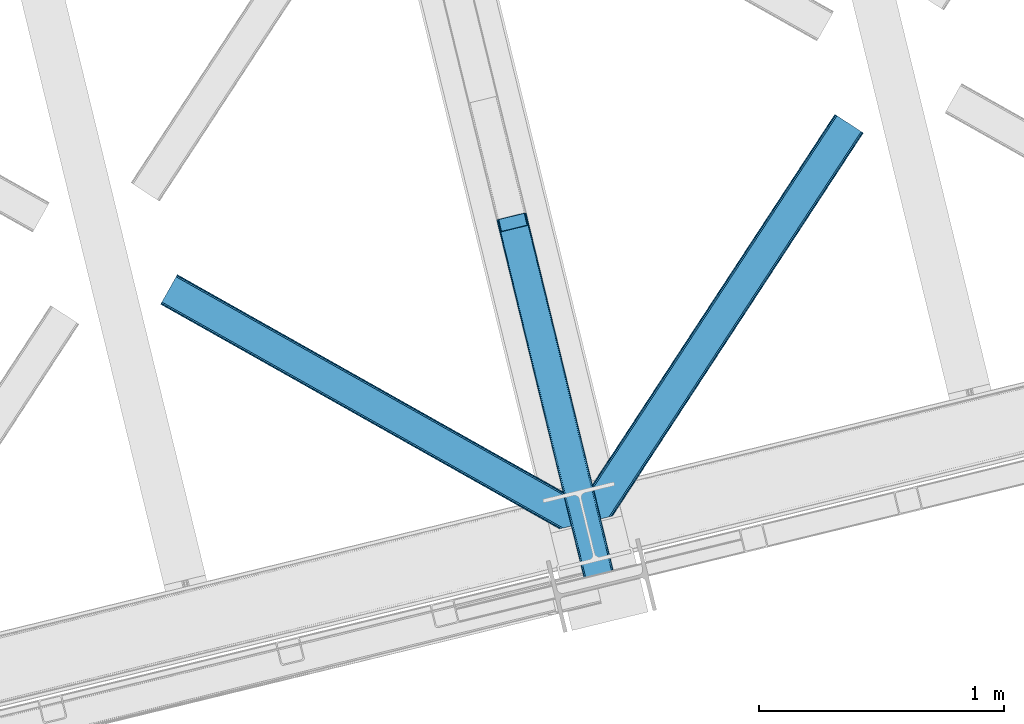
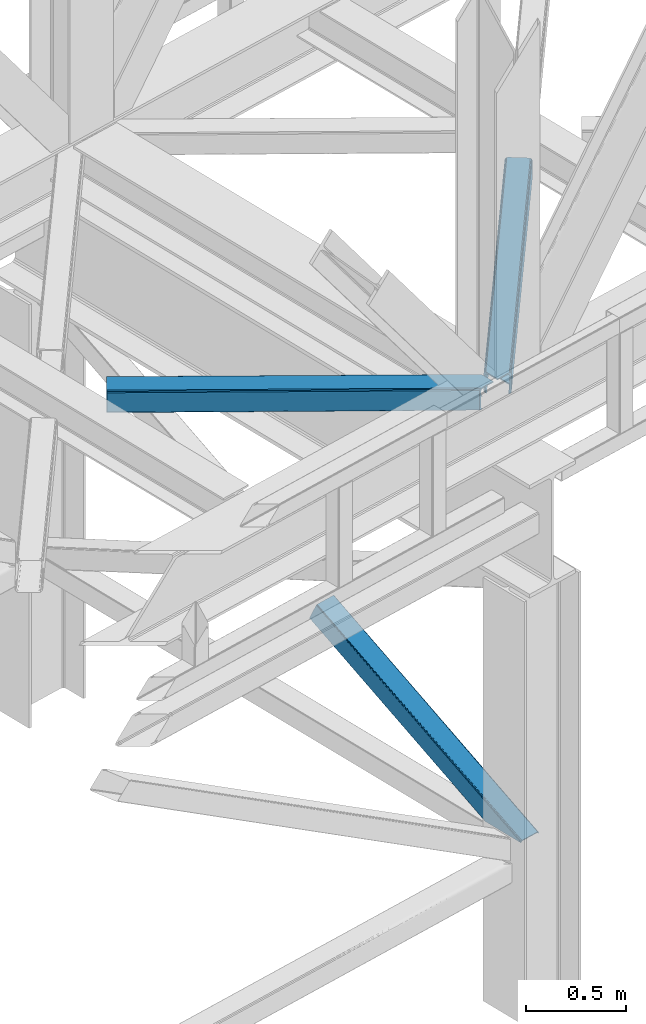
# One storey, part 50 of 93: 3 members.
"""IFC4 building model written with IfcOpenShell, lengths in millimetres."""

import ifcopenshell
import ifcopenshell.guid

model = None  # the IFC model being written
_history = None  # IfcOwnerHistory: only IFC2X3 demands one
_inside = {}  # id of a spatial element -> (the spatial element, [elements in it])
_under = {}  # id of a project, library or spatial element -> (it, [spatial elements below it])
_declared = {}  # id of a project -> (the project, [libraries it declares])
_typed = {}  # id of a type object -> (the type object, [elements of that type])
_made_of = {}  # id of a material, layer set ... -> (it, [elements and type objects made of it])


def new_model(schema):
    """Start an empty IFC model of exactly this schema.

    Asked for "IFC4X3", IfcOpenShell would pick the latest addendum, in which some entities
    have other attributes; the version numbers below select the first issue.
    IFC2X3 requires an IfcOwnerHistory on every rooted entity: one is made here for all.
    """
    global model, _history
    if schema == "IFC4X3":
        model = ifcopenshell.file(schema_version=(4, 3, 0, 0))
    else:
        model = ifcopenshell.file(schema=schema)
    _inside.clear()
    _under.clear()
    _declared.clear()
    _typed.clear()
    _made_of.clear()
    _history = None
    if model.schema == "IFC2X3":
        org = make("IfcOrganization", Name="unknown")
        user = make(
            "IfcPersonAndOrganization",
            ThePerson=make("IfcPerson", FamilyName="unknown"),
            TheOrganization=org,
        )
        app = make(
            "IfcApplication",
            ApplicationDeveloper=org,
            Version="unknown",
            ApplicationFullName="unknown",
            ApplicationIdentifier="unknown",
        )
        _history = make(
            "IfcOwnerHistory",
            OwningUser=user,
            OwningApplication=app,
            ChangeAction="ADDED",
            CreationDate=0,
        )
    return model


def make(cls, **values):
    """One entity of the class cls with the attributes given. An attribute that is None is left unset."""
    return model.create_entity(
        cls, **{name: value for name, value in values.items() if value is not None}
    )


def entity(cls, *values):
    """Any entity or typed value of the class cls, its attributes in the order of the schema. None: left unset."""
    e = model.create_entity(cls)
    for i, value in enumerate(values):
        if value is not None:
            e[i] = value
    return e


def rooted(cls, **values):
    """An entity with a GlobalId (a new one), such as an element, a storey or a relation."""
    return make(cls, GlobalId=ifcopenshell.guid.new(), OwnerHistory=_history, **values)


def si_unit(unit_type, name, prefix=None):
    """IfcSIUnit, for example si_unit("LENGTHUNIT", "METRE", prefix="MILLI")."""
    return make("IfcSIUnit", UnitType=unit_type, Prefix=prefix, Name=name)


def converted_unit(unit_type, name, factor, base, dimensions=None, offset=None):
    """IfcConversionBasedUnit, such as the inch: factor (a typed value) times the base unit."""
    return make(
        "IfcConversionBasedUnit"
        if offset is None
        else "IfcConversionBasedUnitWithOffset",
        ConversionOffset=offset,
        Dimensions=None
        if dimensions is None
        else entity("IfcDimensionalExponents", *dimensions),
        UnitType=unit_type,
        Name=name,
        ConversionFactor=make(
            "IfcMeasureWithUnit", ValueComponent=factor, UnitComponent=base
        ),
    )


def derived_unit(unit_type, elements):
    """IfcDerivedUnit: a product of units, each with its exponent."""
    return make(
        "IfcDerivedUnit",
        Elements=[
            make("IfcDerivedUnitElement", Unit=unit, Exponent=power)
            for unit, power in elements
        ],
        UnitType=unit_type,
    )


def assignment(units):
    """IfcUnitAssignment: the units of a project."""
    return None if units is None else make("IfcUnitAssignment", Units=units)


def point(xyz):
    """IfcCartesianPoint."""
    return None if xyz is None else make("IfcCartesianPoint", Coordinates=xyz)


def direction(xyz):
    """IfcDirection."""
    return None if xyz is None else make("IfcDirection", DirectionRatios=xyz)


def frame(location, z_axis=None, x_axis=None):
    """IfcAxis2Placement3D, a coordinate frame: its origin and axes. An axis left out is left unset."""
    return make(
        "IfcAxis2Placement3D",
        Location=point(location),
        Axis=direction(z_axis),
        RefDirection=direction(x_axis),
    )


def origin():
    """The frame at (0, 0, 0) with its axes left unset."""
    return frame((0.0, 0.0, 0.0))


def place(relative_to, where):
    """IfcLocalPlacement: puts the frame where relative to a parent placement (None: the world)."""
    return make(
        "IfcLocalPlacement", PlacementRelTo=relative_to, RelativePlacement=where
    )


def context(
    kind, dimensions, precision=None, world=None, true_north=None, identifier=None
):
    """IfcGeometricRepresentationContext, for example the 3D "Model" context."""
    return make(
        "IfcGeometricRepresentationContext",
        ContextIdentifier=identifier,
        ContextType=kind,
        CoordinateSpaceDimension=dimensions,
        Precision=precision,
        WorldCoordinateSystem=world,
        TrueNorth=true_north,
    )


def subcontext(parent, identifier, kind, view, scale=None):
    """IfcGeometricRepresentationSubContext, for example "Body" below "Model"."""
    return make(
        "IfcGeometricRepresentationSubContext",
        ContextIdentifier=identifier,
        ContextType=kind,
        ParentContext=parent,
        TargetScale=scale,
        TargetView=view,
    )


def project(units=None, contexts=None):
    """IfcProject with its units and contexts."""
    return rooted(
        "IfcProject",
        Name="project",
        RepresentationContexts=contexts,
        UnitsInContext=assignment(units),
    )


def spatial(cls, under=None, at=None, **own):
    """A site, building, storey or space (cls), placed at a placement, below another one or the project."""
    s = rooted(cls, ObjectPlacement=at, **own)
    if under is not None:
        _under.setdefault(under.id(), (under, []))[1].append(s)
    return s


def point_list(points):
    """IfcCartesianPointList2D or 3D."""
    cls = (
        "IfcCartesianPointList2D" if len(points[0]) == 2 else "IfcCartesianPointList3D"
    )
    return make(cls, CoordList=points)


def triangles(points, corners, closed=None, point_numbers=None):
    """IfcTriangulatedFaceSet: each triangle names its three corners, points numbered from 1."""
    return make(
        "IfcTriangulatedFaceSet",
        Coordinates=point_list(points),
        Closed=closed,
        CoordIndex=corners,
        PnIndex=point_numbers,
    )


def polygons(points, faces, closed=None, point_numbers=None):
    """IfcPolygonalFaceSet: a face is its outer loop, then its inner loops; points numbered from 1."""
    made = []
    for loops in faces:
        if len(loops) == 1:
            made.append(make("IfcIndexedPolygonalFace", CoordIndex=loops[0]))
        else:
            made.append(
                make(
                    "IfcIndexedPolygonalFaceWithVoids",
                    CoordIndex=loops[0],
                    InnerCoordIndices=loops[1:],
                )
            )
    return make(
        "IfcPolygonalFaceSet",
        Coordinates=point_list(points),
        Closed=closed,
        Faces=made,
        PnIndex=point_numbers,
    )


def shape(context_of_items, identifier, shape_type, items):
    """IfcShapeRepresentation: the items that make up one representation, for example the "Body"."""
    return make(
        "IfcShapeRepresentation",
        ContextOfItems=context_of_items,
        RepresentationIdentifier=identifier,
        RepresentationType=shape_type,
        Items=items,
    )


def made_of(thing, what):
    """Note that an element or type object is made of a material, layer set ...; save() writes the relation."""
    if what is not None:
        _made_of.setdefault(what.id(), (what, []))[1].append(thing)
    return thing


def type_object(cls, material=None, **own):
    """A type object (cls), such as IfcWallType, which elements share."""
    return made_of(rooted(cls, **own), material)


def element(
    cls,
    number,
    at=None,
    inside=None,
    cuts=None,
    type_object=None,
    material=None,
    context=None,
    identifier="Body",
    shape_type=None,
    held_by="IfcProductDefinitionShape",
    body=None,
    shapes=None,
    **own,
):
    """One element of the class cls, such as IfcWall. Its Tag is "e" and its number.

    at: its placement. inside: the storey or other place that contains it. cuts: it is an
    opening in that element (IfcRelVoidsElement). A single representation is given by context,
    identifier, shape_type and body (its items); several are given by shapes. held_by: the class
    of the entity that holds the representations. save() writes the other relations.
    """
    e = rooted(cls, Tag="e%d" % number, ObjectPlacement=at, **own)
    if body is not None:
        shapes = [shape(context, identifier, shape_type, body)]
    if shapes is not None:
        e.Representation = make(held_by, Representations=shapes)
    if inside is not None:
        _inside.setdefault(inside.id(), (inside, []))[1].append(e)
    if cuts is not None:
        rooted(
            "IfcRelVoidsElement", RelatingBuildingElement=cuts, RelatedOpeningElement=e
        )
    if type_object is not None:
        _typed.setdefault(type_object.id(), (type_object, []))[1].append(e)
    return made_of(e, material)


def aggregate(whole, parts):
    """IfcRelAggregates: a whole, such as a stair, and the parts it consists of."""
    return rooted("IfcRelAggregates", RelatingObject=whole, RelatedObjects=parts)


def save(model, path):
    """Write the relations noted so far, then the file.

    IfcRelAggregates (storeys below a building ...), IfcRelContainedInSpatialStructure (elements
    in a storey), IfcRelDefinesByType, IfcRelAssociatesMaterial and IfcRelDeclares: one each for
    every whole, place, type object, material and project.
    """
    for whole, parts in _under.values():
        aggregate(whole, parts)
    for where, things in _inside.values():
        rooted(
            "IfcRelContainedInSpatialStructure",
            RelatedElements=things,
            RelatingStructure=where,
        )
    for kind, things in _typed.values():
        rooted("IfcRelDefinesByType", RelatedObjects=things, RelatingType=kind)
    for what, things in _made_of.values():
        rooted("IfcRelAssociatesMaterial", RelatedObjects=things, RelatingMaterial=what)
    for by, libraries in _declared.values():
        rooted("IfcRelDeclares", RelatingContext=by, RelatedDefinitions=libraries)
    model.write(path)


model = new_model("IFC4")

# Units and contexts
model_context = context("Model", 3, precision=0.01, world=origin(), true_north=direction((6.12303176911189e-17, 1.0)))
plan_context = context("Plan", 3, precision=0.01, world=origin(), true_north=direction((6.12303176911189e-17, 1.0)))
body_context = subcontext(model_context, "Body", "Model", "MODEL_VIEW")
ifc_project = project(units=[si_unit("LENGTHUNIT", "METRE", prefix="MILLI"), si_unit("AREAUNIT", "SQUARE_METRE"), si_unit("VOLUMEUNIT", "CUBIC_METRE"), converted_unit("PLANEANGLEUNIT", "DEGREE", entity("IfcRatioMeasure", 0.0174532925199433), si_unit("PLANEANGLEUNIT", "RADIAN"), dimensions=[0, 0, 0, 0, 0, 0, 0]), si_unit("MASSUNIT", "GRAM", prefix="KILO"), derived_unit("MASSDENSITYUNIT", [(si_unit("MASSUNIT", "GRAM", prefix="KILO"), 1), (si_unit("LENGTHUNIT", "METRE"), -3)]), derived_unit("MOMENTOFINERTIAUNIT", [(si_unit("LENGTHUNIT", "METRE"), 4)]), si_unit("TIMEUNIT", "SECOND"), si_unit("FREQUENCYUNIT", "HERTZ"), si_unit("THERMODYNAMICTEMPERATUREUNIT", "DEGREE_CELSIUS"), derived_unit("THERMALTRANSMITTANCEUNIT", [(si_unit("MASSUNIT", "GRAM", prefix="KILO"), 1), (si_unit("THERMODYNAMICTEMPERATUREUNIT", "KELVIN"), -1), (si_unit("TIMEUNIT", "SECOND"), -3)]), derived_unit("VOLUMETRICFLOWRATEUNIT", [(si_unit("LENGTHUNIT", "METRE"), 3), (si_unit("TIMEUNIT", "SECOND"), -1)]), derived_unit("MASSFLOWRATEUNIT", [(si_unit("MASSUNIT", "GRAM", prefix="KILO"), 1), (si_unit("TIMEUNIT", "SECOND"), -1)]), derived_unit("ROTATIONALFREQUENCYUNIT", [(si_unit("TIMEUNIT", "SECOND"), -1)]), si_unit("ELECTRICCURRENTUNIT", "AMPERE"), si_unit("ELECTRICVOLTAGEUNIT", "VOLT"), si_unit("POWERUNIT", "WATT"), si_unit("FORCEUNIT", "NEWTON", prefix="KILO"), si_unit("ILLUMINANCEUNIT", "LUX"), si_unit("LUMINOUSFLUXUNIT", "LUMEN"), si_unit("LUMINOUSINTENSITYUNIT", "CANDELA"), derived_unit("USERDEFINED", [(si_unit("MASSUNIT", "GRAM", prefix="KILO"), -1), (si_unit("LENGTHUNIT", "METRE"), -2), (si_unit("TIMEUNIT", "SECOND"), 3), (si_unit("LUMINOUSFLUXUNIT", "LUMEN"), 1)]), derived_unit("LINEARVELOCITYUNIT", [(si_unit("LENGTHUNIT", "METRE"), 1), (si_unit("TIMEUNIT", "SECOND"), -1)]), si_unit("PRESSUREUNIT", "PASCAL"), derived_unit("USERDEFINED", [(si_unit("LENGTHUNIT", "METRE"), -2), (si_unit("MASSUNIT", "GRAM", prefix="KILO"), 1), (si_unit("TIMEUNIT", "SECOND"), -2)]), derived_unit("LINEARFORCEUNIT", [(si_unit("MASSUNIT", "GRAM", prefix="KILO"), 1), (si_unit("LENGTHUNIT", "METRE"), 1), (si_unit("TIMEUNIT", "SECOND"), -2), (si_unit("LENGTHUNIT", "METRE"), -1)]), derived_unit("PLANARFORCEUNIT", [(si_unit("MASSUNIT", "GRAM", prefix="KILO"), 1), (si_unit("LENGTHUNIT", "METRE"), 1), (si_unit("TIMEUNIT", "SECOND"), -2), (si_unit("LENGTHUNIT", "METRE"), -2)])], contexts=[model_context, plan_context])

# Site, building, storey
site_placement = place(None, origin())
site = spatial("IfcSite", under=ifc_project, at=site_placement, CompositionType="ELEMENT")
building_placement = place(site_placement, origin())
building = spatial("IfcBuilding", under=site, at=building_placement, CompositionType="ELEMENT")
storey_placement = place(building_placement, frame((0.0, 0.0, 15900.0)))
storey = spatial("IfcBuildingStorey", under=building, at=storey_placement, CompositionType="ELEMENT", Elevation=15900.0)

# Members
member_type_1 = type_object("IfcMemberType", PredefinedType="BRACE")
member_1_placement = place(storey_placement, frame((-36161.5055157811, 8634.38106460785, 970.499999998947)))
element("IfcMember", 1, at=member_1_placement, inside=storey, type_object=member_type_1, ObjectType="Steel Vertical Brace", PredefinedType="BRACE", context=body_context, shape_type="Tessellation", body=[
    polygons([(310.156875969815, 236.659699185642, 1.04388391264365e-09), (309.042346364978, 243.803283956976, 1.04388391264365e-09), (4.57230123623604, 1492.85694714149, 603.530503671961), (4.2887644560269, 1491.44877039324, 606.301796687595), (309.280773738945, 250.147759710232, 1.04388391264365e-09), (5.99595206162693, 1494.33917875156, 601.181114896124), (310.835859685345, 254.727237524779, 1.05038111541944e-09), (8.34297899943531, 1495.6698088973, 599.611303503947), (313.47085646575, 256.844533416439, 1.04171817838505e-09), (11.256068474249, 1496.64626120118, 599.060059049496), (366.444630080972, 5.74560241384962, 1.00706643024751e-09), (14.4533090982431, 1449.74988433501, 697.72873436856), (411.597614338024, 280.763968808462, 1.04171817838505e-09), (109.382826346531, 1520.5656965932, 599.060059049498), (425.485457020332, 274.460769180909, 1.03522097560926e-09), (485.172065028795, 29.6032616237788, 9.24768528420827e-10), (481.013627176891, 28.5895984014809, 9.24768528420827e-10), (480.116220883526, 33.4542552937189, 9.72414682109957e-10), (423.82846677236, 264.368352065509, 1.03305524135067e-09), (421.530657217855, 271.223499830256, 1.03522097560926e-09), (418.399388388628, 276.746576483304, 1.03738670986786e-09), (414.911367578924, 280.096743671032, 1.04171817838505e-09), (367.88649561307, 1.0136632218215, 9.29099996938021e-10), (363.728057761106, 2.16573425859679e-12, 5.76085312786745e-10), (304.041449752642, 244.857507557118, 1.03522097560926e-09), (302.926920147815, 252.001092328461, 1.04171817838505e-09), (303.165347521768, 258.345568081721, 1.03738670986786e-09), (304.720433468177, 262.925045896267, 1.04604964690225e-09), (307.355430248578, 265.042341787915, 1.04388391264365e-09), (413.254604585991, 290.856385923861, 1.04604964690225e-09), (416.568357826891, 290.189160786438, 1.04604964690225e-09), (420.056378636596, 286.838993598711, 1.04171817838505e-09), (423.187647465814, 281.315916945663, 1.04171817838505e-09), (112.418486893023, 1521.03931504355, 599.611303503942), (115.114566711319, 1520.93799552464, 601.181114896124), (117.060612089108, 1520.27716301477, 603.530503671961), (117.960355258563, 1519.15742327311, 606.301796687595), (128.124899900792, 1477.45853721488, 697.72873436856), (127.841363120579, 1476.05036046663, 700.500027384193), (126.417712295192, 1474.56812885655, 702.849416160034), (124.070685357384, 1473.23749871082, 704.419227552215), (121.15759588257, 1472.26104640693, 704.970472006657), (23.0308380102795, 1448.34161101491, 704.970472006657), (19.9951774637964, 1447.86799256457, 704.419227552218), (17.2990976455005, 1447.96931208348, 702.849416160031), (15.3530522677154, 1448.63014459335, 700.500027384193), (112.866478355636, 1523.16444199718, 595.439190230451), (6.96730401822207, 1497.35039786123, 595.439190230448), (4.05421454341707, 1496.37394555734, 595.990434684895), (1.70718760560436, 1495.04331541162, 597.56024607707), (0.28353678022213, 1493.56108380154, 599.909634852913), (0.0, 1492.15290705329, 602.680927868548), (10.9696570891299, 1447.15113893104, 701.349603187608), (11.8694002585979, 1446.03139918938, 704.120896203242), (13.8154456363916, 1445.37056667951, 706.470284979081), (16.5115254546875, 1445.2692471606, 708.040096371263), (19.5471860011707, 1445.74286561094, 708.591340825705), (125.446360338589, 1471.55690974689, 708.591340825705), (128.359449813402, 1472.53336205077, 708.040096371265), (130.706476751211, 1473.8639921965, 706.470284979079), (132.130127576593, 1475.34622380658, 704.120896203244), (132.413664356815, 1476.75440055483, 701.349603187608), (121.44400726769, 1521.75616867708, 602.680927868548), (120.544264098226, 1522.87590841874, 599.909634852913), (118.598218720428, 1523.53674092861, 597.560246077077), (115.902138902128, 1523.63806044752, 595.990434684897), (375.386682458807, 2.84191311588486, 6.51916727653314), (372.638718264457, 2.17206777061844, 5.2249222388966), (369.890754070107, 1.50222242536393, 3.93067720123624), (368.37332664802, 1.13233343716275, 0.954754934343811), (480.407239661998, 28.4417850297788, 0.783330976602792), (478.425418155208, 27.9586950702373, 3.34344663920135), (476.487815341744, 27.4863838850221, 5.84644062407408), (473.513440331089, 26.761348507908, 6.51916727653314), (485.1720650288, 29.6032616237626, 2.10033831597304), (484.033820990584, 29.325802597071, 5.22492223888794), (482.895576952364, 29.0483435703718, 8.34950616180717), (480.147612758018, 28.3784982251097, 9.64375119945237), (477.399648563664, 27.7086528798498, 10.9379962370932), (371.500474226237, 1.89460874392252, 10.9379962370954), (368.752510031891, 1.22476339866151, 9.64375119945237), (366.004545837554, 0.55491805340375, 8.34950616180934), (364.866301799321, 0.277459026700251, 5.2249222388901), (363.728057761106, 2.16573425859679e-12, 2.10033831597304)], [[[1, 2, 3, 4]], [[2, 5, 6, 3]], [[5, 7, 8, 6]], [[7, 9, 10, 8]], [[11, 1, 4, 12]], [[9, 13, 14, 10]], [[15, 16, 17, 18, 19, 20, 21, 22, 13, 9, 7, 5, 2, 1, 11, 23, 24, 25, 26, 27, 28, 29, 30, 31, 32, 33]], [[47, 48, 49, 50, 51, 52, 53, 54, 55, 56, 57, 58, 59, 60, 61, 62, 63, 64, 65, 66], [10, 14, 34, 35, 36, 37, 38, 39, 40, 41, 42, 43, 44, 45, 46, 12, 4, 3, 6, 8]], [[13, 22, 34, 14]], [[22, 21, 35, 34]], [[21, 20, 36, 35]], [[20, 19, 37, 36]], [[19, 18, 38, 37]], [[44, 67, 68]], [[45, 68, 69]], [[46, 69, 70]], [[46, 11, 12]], [[11, 70, 23]], [[11, 46, 70]], [[69, 46, 45]], [[68, 45, 44]], [[67, 44, 43]], [[71, 18, 17]], [[39, 72, 40]], [[40, 73, 41]], [[73, 74, 42, 41]], [[73, 40, 72]], [[72, 39, 71]], [[39, 18, 71]], [[18, 39, 38]], [[42, 74, 67, 43]], [[16, 75, 76, 77, 78, 79, 80, 81, 82, 83, 84, 24, 23, 70, 69, 68, 67, 74, 73, 72, 71, 17]], [[29, 28, 49, 48]], [[28, 27, 50, 49]], [[27, 26, 51, 50]], [[26, 25, 52, 51]], [[47, 30, 29, 48]], [[15, 33, 64, 63]], [[33, 32, 65, 64]], [[32, 31, 66, 65]], [[31, 30, 47, 66]], [[24, 84, 53, 52, 25]], [[75, 16, 15, 63, 62]], [[53, 83, 54]], [[54, 82, 55]], [[55, 81, 56]], [[56, 80, 57]], [[80, 56, 81]], [[81, 55, 82]], [[82, 54, 83]], [[83, 53, 84]], [[80, 79, 58, 57]], [[59, 79, 78]], [[60, 78, 77]], [[61, 77, 76]], [[62, 76, 75]], [[76, 62, 61]], [[77, 61, 60]], [[78, 60, 59]], [[79, 59, 58]]], closed=True),
])
member_type_2 = type_object("IfcMemberType", PredefinedType="BRACE")
member_2_placement = place(storey_placement, frame((-35805.5772583008, 8895.6233001709, 3511.0000579834)))
element("IfcMember", 2, at=member_2_placement, inside=storey, type_object=member_type_2, ObjectType="Steel Horizontal Brace", PredefinedType="BRACE", context=body_context, shape_type="Tessellation", body=[
    triangles([(109.770043945318, 259.949830627442, 7.52047119140843), (115.030187988283, 238.365682983398, 7.77510681152489), (114.216284179689, 239.946981811523, 8.3320495605476), (108.809637451173, 259.662638854981, 8.52041015625218), (113.637249755862, 239.859777832031, 8.52041015625218), (112.20710449219, 237.677352905273, 8.52041015625218), (91.0339782714873, 232.516621398925, 8.52041015625218), (109.535174560551, 237.025648498535, 9.50058288574292), (90.2619323730469, 232.328260803222, 9.50058288574292), (5.0206237793027, 77.405158996582, 9.50058288574292), (0.625543212896446, 95.4308029174808, 9.50058288574292), (1046.62216186523, 1651.75382995605, 6.99957275390625), (1041.02017822266, 1655.42221069336, 8.3320495605476), (116.699853515631, 231.514938354492, 6.99957275390625), (1036.26930541993, 1658.53132324219, 12.1260040283232), (3.92999267578125, 81.8752349853512, 12.1260040283232), (1033.09740600587, 1660.61026611328, 17.8035644531265), (2.69983520507958, 86.9220199584961, 17.8035644531265), (1031.98352050781, 1661.34045410156, 24.4996673583992), (2.26962890625146, 88.6940048217766, 24.4996673583992), (1122.7547241211, 1601.90454711914, 6.99957275390625), (146.209680175787, 110.459536743165, 6.99957275390625), (1031.98352050781, 1661.34045410156, 115.501089477541), (2.26962890625146, 88.6940048217766, 115.501089477541), (1033.09740600587, 1660.61026611328, 122.196029663086), (2.69983520507958, 86.9220199584961, 122.196029663086), (1036.26930541993, 1658.53132324219, 127.87475280762), (3.92999267578125, 81.8752349853512, 127.87475280762), (1041.02017822266, 1655.42221069336, 131.667544555665), (5.77174072265916, 74.3227890014641, 131.667544555665), (1046.62216186523, 1651.75382995605, 133.000021362306), (7.94370117187646, 65.4140304565426, 133.000021362306), (1027.24194946289, 1664.44491577148, 10.8028289794929), (0.518572998051241, 95.8714736938473, 10.8691040039084), (0.0, 98.0056457519531, 17.5000946044929), (1035.16472167969, 1659.25686035156, 1.33247680664135), (112.260589599609, 249.73533782959, 1.33247680664135), (110.544415283206, 256.772117614746, 5.59500732422021), (109.077062988283, 259.839372253418, 8.31925964355469), (1030.41384887695, 1662.36597290039, 5.12526855468968), (1040.76670532227, 1655.58847961426, 0.0), (114.430224609379, 240.826579284669, 0.0), (1026.12573852539, 1665.17394104004, 17.5000946044929), (1128.61250610352, 1598.06989746094, 0.0), (148.479309082031, 101.147314453125, 0.0), (150.651269531256, 92.2385559082031, 1.33247680664135), (148.507214355472, 101.029298400879, 8.50064392089917), (152.493017578126, 84.686109924316, 5.12526855468968), (153.346453857426, 81.182254028321, 8.50064392089917), (1026.12573852539, 1665.17394104004, 122.500662231447), (0.0, 98.0056457519531, 122.500662231447), (1040.76670532227, 1655.58847961426, 139.999594116212), (1035.16472167969, 1659.25686035156, 138.667117309571), (3.50211181640771, 83.6350112915043, 138.667117309571), (5.674072265625, 74.7256713867191, 139.999594116212), (1030.41384887695, 1662.36597290039, 134.874325561526), (1.66036376953707, 91.1874572753914, 134.874325561526), (1027.24194946289, 1664.44491577148, 129.197927856447), (0.430206298828125, 96.2336608886726, 129.197927856447), (23.8892395019575, 0.0, 139.999594116212), (23.8892395019575, 0.0, 133.000021362306), (1128.61250610352, 1598.06989746094, 139.999594116212), (93.3338378906265, 16.9280364990227, 139.999594116212), (1122.7547241211, 1601.90454711914, 133.000021362306), (83.3786315917969, 14.5008590698235, 133.000021362306), (1143.2534729004, 1588.48443603516, 122.500662231447), (1142.1372619629, 1589.21346130371, 129.197927856447), (118.225341796875, 22.9951080322262, 122.500662231447), (116.330108642578, 22.5335083007813, 129.197927856447), (1138.96536254883, 1591.29124145508, 134.874325561526), (110.935089111328, 21.2178909301765, 134.874325561526), (1134.2144897461, 1594.40151672363, 138.667117309571), (102.861163330082, 19.2499877929695, 138.667117309571), (1143.2534729004, 1588.48443603516, 17.5000946044929), (118.225341796875, 22.9951080322262, 17.5000946044929), (1142.1372619629, 1589.21346130371, 10.8028289794929), (1133.10758056641, 1595.12589111328, 12.1260040283232), (1136.28180541992, 1593.04811096191, 17.8035644531265), (1137.39569091797, 1592.31792297363, 24.4996673583992), (1138.96536254883, 1591.29124145508, 5.12526855468968), (1134.2144897461, 1594.40151672363, 1.33247680664135), (1128.35903320313, 1598.23616638184, 8.3320495605476), (1133.10758056641, 1595.12589111328, 127.87475280762), (1137.39569091797, 1592.31792297363, 115.501089477541), (1136.28180541992, 1593.04811096191, 122.196029663086), (1128.35903320313, 1598.23616638184, 131.667544555665), (92.9036315917983, 16.8228103637703, 131.667544555665), (100.977557373051, 18.7912948608391, 127.87475280762), (106.372576904301, 20.106330871582, 122.196029663086), (108.267810058598, 20.5685119628906, 115.501089477541), (108.267810058598, 20.5685119628906, 24.4996673583992), (100.977557373051, 18.7912948608391, 12.1260040283232), (115.472021484376, 22.32421875, 9.50058288574292), (106.372576904301, 20.106330871582, 17.8035644531265), (96.1987792968794, 17.6262496948239, 9.50058288574292), (115.944085693365, 22.439328002929, 10.8702667236357), (153.060424804688, 80.2392883300781, 9.00061340332104), (152.776721191411, 79.2969039916989, 9.50058288574292), (148.711853027344, 99.8677413940422, 8.8831787109375), (148.602557373051, 99.023606872559, 9.08781738281323), (148.490936279297, 98.1666824340828, 9.29478149414354), (148.381640625004, 97.3231292724613, 9.50058288574292)], [[1, 2, 3], [4, 5, 6], [6, 7, 4], [7, 6, 8], [8, 9, 7], [9, 8, 10], [10, 11, 9], [12, 13, 3], [3, 2, 12], [2, 14, 12], [15, 16, 8], [8, 13, 15], [8, 5, 13], [16, 10, 8], [8, 6, 5], [15, 17, 18], [18, 16, 15], [17, 19, 20], [20, 18, 17], [21, 12, 14], [14, 22, 21], [19, 23, 20], [24, 20, 23], [23, 25, 24], [26, 24, 25], [25, 27, 26], [28, 26, 27], [27, 29, 28], [30, 28, 29], [29, 31, 30], [32, 30, 31], [33, 34, 35], [36, 37, 38], [33, 4, 9], [33, 1, 39], [9, 34, 33], [9, 11, 34], [4, 7, 9], [40, 38, 1], [1, 33, 40], [38, 40, 36], [36, 41, 37], [42, 37, 41], [35, 43, 33], [41, 44, 42], [45, 42, 44], [14, 42, 22], [37, 2, 38], [2, 37, 42], [38, 2, 1], [42, 14, 2], [22, 42, 45], [46, 47, 45], [47, 46, 48], [45, 47, 22], [48, 49, 47], [50, 43, 35], [35, 51, 50], [52, 53, 54], [54, 55, 52], [53, 56, 57], [57, 54, 53], [56, 58, 59], [59, 57, 56], [58, 50, 51], [51, 59, 58], [28, 57, 26], [30, 32, 55], [32, 60, 55], [32, 61, 60], [54, 30, 55], [28, 54, 57], [16, 11, 10], [28, 30, 54], [51, 35, 20], [24, 26, 51], [24, 51, 20], [57, 59, 26], [26, 59, 51], [35, 18, 20], [18, 11, 16], [11, 18, 34], [35, 34, 18], [62, 55, 63], [62, 52, 55], [55, 60, 63], [64, 32, 31], [32, 64, 65], [61, 32, 65], [66, 67, 68], [69, 68, 67], [67, 70, 69], [71, 69, 70], [70, 72, 71], [73, 71, 72], [72, 62, 73], [63, 73, 62], [74, 66, 75], [68, 75, 66], [76, 77, 78], [79, 66, 74], [76, 78, 74], [76, 80, 77], [78, 79, 74], [77, 80, 81], [21, 44, 41], [44, 82, 81], [82, 44, 21], [82, 77, 81], [67, 83, 70], [84, 66, 79], [66, 85, 67], [85, 66, 84], [67, 85, 83], [62, 64, 52], [72, 70, 83], [83, 86, 72], [86, 64, 62], [62, 72, 86], [15, 36, 40], [41, 12, 21], [41, 13, 12], [13, 41, 36], [15, 13, 36], [19, 43, 50], [33, 17, 15], [40, 33, 15], [17, 33, 43], [19, 17, 43], [53, 27, 56], [52, 64, 31], [31, 29, 52], [29, 27, 53], [53, 52, 29], [58, 56, 27], [50, 23, 19], [25, 50, 58], [50, 25, 23], [25, 58, 27], [64, 86, 87], [87, 65, 64], [86, 83, 88], [88, 87, 86], [83, 85, 89], [89, 88, 83], [85, 84, 90], [90, 89, 85], [84, 79, 90], [91, 90, 79], [89, 68, 69], [87, 73, 63], [60, 65, 63], [65, 60, 61], [65, 87, 63], [88, 73, 87], [88, 89, 71], [71, 73, 88], [69, 71, 89], [91, 75, 68], [92, 93, 94], [89, 90, 68], [92, 95, 93], [91, 94, 75], [90, 91, 68], [96, 75, 94], [94, 93, 96], [76, 74, 75], [49, 80, 97], [98, 97, 80], [49, 48, 80], [76, 96, 98], [98, 80, 76], [96, 93, 98], [44, 81, 45], [46, 45, 81], [81, 80, 46], [48, 46, 80], [75, 96, 76], [82, 21, 22], [77, 82, 47], [47, 99, 77], [77, 100, 101], [100, 77, 99], [101, 102, 77], [77, 102, 92], [95, 92, 102], [22, 47, 82], [79, 78, 91], [94, 91, 78], [78, 77, 94], [92, 94, 77], [102, 101, 98], [101, 100, 97], [100, 99, 49], [99, 47, 49], [102, 98, 93], [93, 95, 102]]),
])
member_type_3 = type_object("IfcMemberType", PredefinedType="BRACE")
member_3_placement = place(storey_placement, frame((-37535.6228210449, 8865.52281188965, 3511.0000579834)))
element("IfcMember", 3, at=member_3_placement, inside=storey, type_object=member_type_3, ObjectType="Steel Horizontal Brace", PredefinedType="BRACE", context=body_context, shape_type="Tessellation", body=[
    triangles([(1645.81582031251, 3.74512023925854, 138.667117309571), (1655.3408203125, 6.06707153320349, 139.999594116212), (8.58784790039499, 933.436047363282, 139.999594116212), (5.302001953125, 927.601519775391, 138.667117309571), (1637.74189453125, 1.77721710205151, 134.874325561526), (2.51612548828416, 922.654147338868, 134.874325561526), (1632.346875, 0.462181091308594, 129.197927856447), (0.65577392578416, 919.34853515625, 129.197927856447), (1630.45164184571, 0.0, 122.500662231447), (0.0, 918.188140869141, 122.500662231447), (1630.45164184571, 0.0, 17.5000946044929), (0.0, 918.188140869141, 17.5000946044929), (1706.5725769043, 97.721360778809, 139.999594116212), (1724.78774414063, 22.9951080322262, 139.999594116212), (60.1102844238339, 1024.92581176758, 139.999594116212), (1701.3287109375, 119.229350280762, 129.197927856447), (1700.89850463867, 121.001335144043, 122.500662231447), (68.0446838378921, 1039.01332397461, 129.197927856447), (68.6981323242217, 1040.17488098145, 122.500662231447), (1702.5588684082, 114.182565307618, 134.874325561526), (66.1820068359375, 1035.70887451172, 134.874325561526), (1704.40061645508, 106.63011932373, 138.667117309571), (63.3961303710967, 1030.7615020752, 138.667117309571), (1700.89850463867, 121.001335144043, 17.5000946044929), (68.6981323242217, 1040.17488098145, 17.5000946044929), (0.65577392578416, 919.34853515625, 10.8028289794929), (1633.02822875977, 0.628450012207395, 10.9377044677749), (2.51612548828416, 922.654147338868, 5.12526855468968), (5.302001953125, 927.601519775391, 1.33247680664135), (1569.7995300293, 46.554135131837, 1.33247680664135), (1573.68999023438, 34.8100845336921, 8.52041015625218), (1571.51337890625, 39.517936706543, 5.59500732422021), (1572.28775024414, 36.3396423339855, 7.52047119140843), (1573.35047607422, 35.1804107666012, 8.278564453125), (1572.99003295899, 35.5751541137706, 8.02044067383031), (1572.6272644043, 35.9693161010746, 7.76231689453198), (1633.97700805665, 0.859831237792605, 8.52041015625218), (1567.62756958008, 55.4634750366222, 0.0), (8.58784790039499, 933.436047363282, 0.0), (1533.57848510743, 195.142739868164, 0.0), (60.1102844238339, 1024.92581176758, 0.0), (1566.72994995117, 59.1411575317379, 7.52047119140843), (1567.24852294922, 57.3430114746097, 7.90300598144677), (1567.7856994629, 56.436090087891, 8.1076446533225), (1568.32752685547, 55.5198669433594, 8.31460876464917), (1568.41124267579, 55.37627105713, 8.3471649169951), (1568.86237792969, 54.6129455566406, 8.52041015625218), (1655.15013427735, 6.02056274414099, 8.52041015625218), (5.9507995605527, 928.753775024414, 12.1260040283232), (1647.69942626954, 4.20439453125073, 12.1260040283232), (8.73667602539354, 933.699984741212, 8.3320495605476), (12.0225219726563, 939.535675048828, 6.99957275390625), (1565.35794067383, 64.7751159667969, 6.99957275390625), (1642.30208129883, 2.88819580078234, 17.8035644531265), (4.0904479980527, 925.448162841798, 17.8035644531265), (1640.40684814454, 2.42717742919922, 24.4996673583992), (3.43467407226854, 924.286605834961, 24.4996673583992), (1640.40684814454, 2.42717742919922, 115.501089477541), (3.43467407226854, 924.286605834961, 115.501089477541), (1647.69942626954, 4.20439453125073, 127.87475280762), (1655.77335205078, 6.17229766845776, 131.667544555665), (1642.30208129883, 2.88819580078234, 122.196029663086), (1665.29835205078, 8.49424896240271, 133.000021362306), (1724.78774414063, 22.9951080322262, 133.000021362306), (4.0904479980527, 925.448162841798, 122.196029663086), (5.9507995605527, 928.753775024414, 127.87475280762), (8.73667602539354, 933.699984741212, 131.667544555665), (12.0225219726563, 939.535675048828, 133.000021362306), (1708.84220581055, 88.4097198486324, 133.000021362306), (56.6756103515654, 1018.82734680176, 133.000021362306), (1535.84811401367, 185.830517578126, 6.99957275390625), (56.6756103515654, 1018.82734680176, 6.99957275390625), (68.0446838378921, 1039.01332397461, 10.8028289794929), (62.7496582031308, 1029.60924682617, 12.1260040283232), (64.6100097656308, 1032.91485900879, 17.8035644531265), (65.2634582519531, 1034.0752532959, 24.4996673583992), (66.1820068359375, 1035.70887451172, 5.12526855468968), (63.3961303710967, 1030.7615020752, 1.33247680664135), (59.9614562988281, 1024.66187438965, 8.3320495605476), (62.7496582031308, 1029.60924682617, 127.87475280762), (65.2634582519531, 1034.0752532959, 115.501089477541), (64.6100097656308, 1032.91485900879, 122.196029663086), (59.9614562988281, 1024.66187438965, 131.667544555665), (1703.16813354492, 111.689694213868, 24.4996673583992), (1703.16813354492, 111.689694213868, 115.501089477541), (1706.67024536133, 97.3184783935558, 131.667544555665), (1704.82849731445, 104.870924377441, 127.87475280762), (1703.59833984375, 109.917127990722, 122.196029663086), (1704.82849731445, 104.870924377441, 12.1260040283232), (1706.52839355469, 97.899838256837, 8.52041015625218), (1701.70078125, 117.702699279786, 8.52041015625218), (1703.59833984375, 109.917127990722, 17.8035644531265), (1701.48451538086, 118.590435791017, 10.9365417480476), (1534.47610473633, 191.464476013183, 7.52047119140843), (1529.69267578125, 211.08769683838, 5.59500732422021), (1528.91597900391, 214.265991210938, 7.52047119140843), (1531.4065246582, 204.051498413086, 1.33247680664135), (1529.11596679688, 214.689221191407, 8.22740478515698), (1529.01597290039, 214.477606201172, 7.87393798828271), (1529.90196533204, 214.452026367188, 8.52041015625218), (1534.35053100586, 192.705097961427, 7.85649719238427), (1534.72725219727, 194.649165344239, 8.52041015625218)], [[1, 2, 3], [3, 4, 1], [5, 1, 4], [4, 6, 5], [7, 5, 6], [6, 8, 7], [9, 7, 8], [8, 10, 9], [11, 9, 10], [10, 12, 11], [2, 13, 3], [2, 14, 13], [15, 3, 13], [16, 17, 18], [19, 18, 17], [20, 16, 21], [18, 21, 16], [22, 20, 23], [21, 23, 20], [13, 22, 15], [23, 15, 22], [17, 24, 19], [25, 19, 24], [26, 27, 11], [28, 29, 30], [27, 26, 31], [26, 28, 32], [32, 33, 26], [34, 26, 35], [34, 31, 26], [26, 36, 35], [26, 33, 36], [31, 37, 27], [30, 32, 28], [38, 30, 29], [29, 39, 38], [11, 12, 26], [40, 38, 39], [39, 41, 40], [33, 42, 43], [36, 43, 44], [35, 44, 45], [34, 46, 47], [34, 45, 46], [47, 31, 34], [45, 34, 35], [44, 35, 36], [43, 36, 33], [48, 37, 47], [31, 47, 37], [49, 50, 47], [47, 51, 49], [47, 46, 51], [50, 48, 47], [52, 43, 42], [51, 46, 45], [45, 52, 51], [45, 44, 52], [43, 52, 44], [42, 53, 52], [54, 50, 49], [49, 55, 54], [56, 54, 55], [55, 57, 56], [58, 56, 59], [57, 59, 56], [60, 61, 1], [5, 60, 1], [5, 7, 62], [60, 5, 62], [62, 7, 9], [61, 2, 1], [14, 63, 64], [14, 2, 63], [61, 63, 2], [62, 9, 58], [56, 11, 54], [9, 56, 58], [11, 27, 54], [9, 11, 56], [37, 54, 27], [50, 54, 37], [48, 50, 37], [62, 58, 65], [59, 65, 58], [60, 62, 66], [65, 66, 62], [61, 60, 67], [66, 67, 60], [63, 61, 68], [67, 68, 61], [69, 63, 68], [63, 69, 64], [68, 70, 69], [53, 71, 52], [72, 52, 71], [73, 74, 75], [76, 19, 25], [73, 75, 25], [73, 77, 74], [75, 76, 25], [74, 77, 78], [72, 41, 39], [41, 79, 78], [79, 41, 72], [79, 74, 78], [18, 80, 21], [81, 19, 76], [19, 82, 18], [82, 19, 81], [18, 82, 80], [15, 70, 3], [23, 21, 80], [80, 83, 23], [83, 70, 15], [15, 23, 83], [49, 29, 28], [39, 52, 72], [39, 51, 52], [51, 39, 29], [49, 51, 29], [57, 12, 10], [26, 55, 49], [28, 26, 49], [55, 26, 12], [57, 55, 12], [4, 66, 6], [3, 70, 68], [68, 67, 3], [67, 66, 4], [4, 3, 67], [8, 6, 66], [10, 59, 57], [65, 10, 8], [10, 65, 59], [65, 8, 66], [84, 85, 76], [81, 76, 85], [86, 69, 70], [70, 83, 86], [87, 86, 83], [83, 80, 87], [88, 87, 80], [80, 82, 88], [85, 88, 82], [82, 81, 85], [87, 20, 22], [89, 90, 91], [20, 87, 88], [86, 87, 22], [86, 13, 69], [14, 69, 13], [69, 14, 64], [86, 22, 13], [24, 17, 84], [91, 92, 89], [92, 24, 84], [93, 92, 91], [93, 24, 92], [17, 85, 84], [88, 16, 20], [17, 16, 88], [85, 17, 88], [40, 71, 53], [94, 95, 96], [40, 94, 71], [94, 97, 95], [94, 40, 97], [38, 40, 53], [42, 38, 53], [32, 42, 33], [42, 30, 38], [42, 32, 30], [73, 25, 24], [98, 99, 77], [96, 77, 99], [96, 95, 77], [73, 93, 100], [100, 77, 73], [100, 98, 77], [93, 91, 100], [78, 77, 95], [97, 40, 41], [41, 78, 97], [95, 97, 78], [24, 93, 73], [72, 71, 94], [94, 79, 72], [101, 102, 79], [79, 94, 101], [74, 79, 102], [90, 89, 102], [74, 102, 89], [92, 84, 75], [76, 75, 84], [89, 92, 74], [75, 74, 92], [101, 94, 99], [102, 101, 99], [91, 90, 102], [102, 100, 91]]),
])

save(model, "model.ifc")
